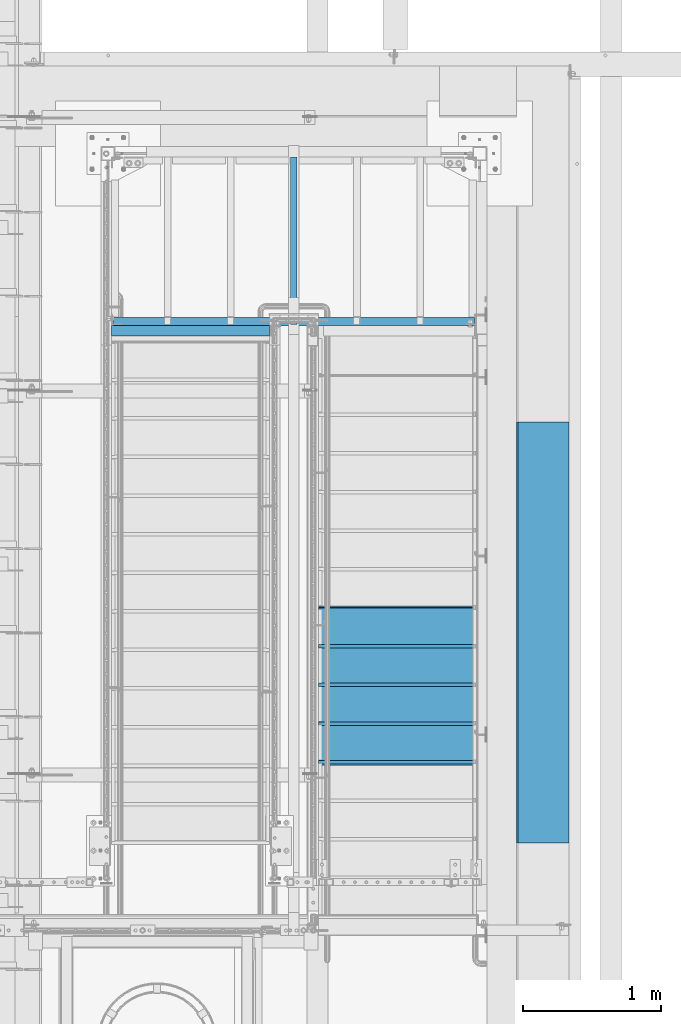
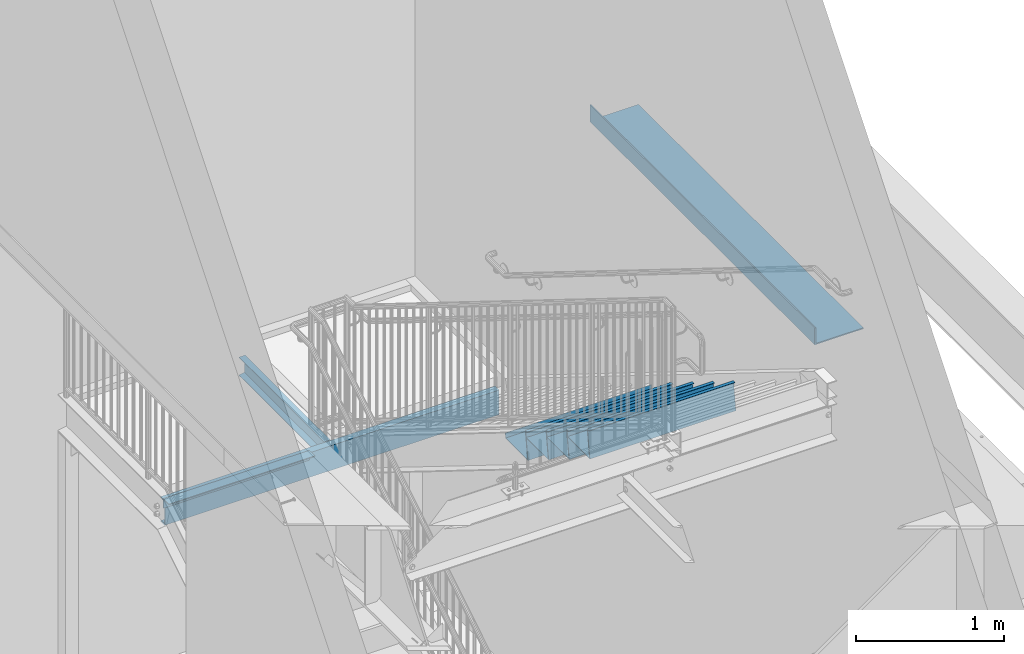
# One storey, part 1093 of 1763: 8 beams, 3 elements without a shape of their own.
"""IFC2X3 building model written with IfcOpenShell, lengths in millimetres."""

from ifc_helpers import new_model, si_unit, frame, origin_with_axes, place, context, subcontext, project, spatial, faceted_brep, material, type_object, element, aggregate, save


model = new_model("IFC2X3")

# Units and contexts
model_context = context("Model", 3, precision=1e-05, world=origin_with_axes())
body_context = subcontext(model_context, "Body", "Model", "MODEL_VIEW")
ifc_project = project(units=[si_unit("LENGTHUNIT", "METRE", prefix="MILLI"), si_unit("AREAUNIT", "SQUARE_METRE"), si_unit("VOLUMEUNIT", "CUBIC_METRE"), si_unit("MASSUNIT", "GRAM", prefix="KILO"), si_unit("TIMEUNIT", "SECOND"), si_unit("PLANEANGLEUNIT", "RADIAN"), si_unit("SOLIDANGLEUNIT", "STERADIAN"), si_unit("THERMODYNAMICTEMPERATUREUNIT", "DEGREE_CELSIUS"), si_unit("LUMINOUSINTENSITYUNIT", "LUMEN")], contexts=[model_context])

# Site, building, storey
site_placement = place(None, origin_with_axes())
site = spatial("IfcSite", under=ifc_project, at=site_placement, CompositionType="ELEMENT")
building_placement = place(site_placement, origin_with_axes())
building = spatial("IfcBuilding", under=site, at=building_placement, Name="Undefined", CompositionType="ELEMENT")
storey_placement = place(building_placement, origin_with_axes())
storey = spatial("IfcBuildingStorey", under=building, at=storey_placement, Name="Undefined", CompositionType="ELEMENT", Elevation=0.0)

# Assembly, beams
assembly_1_placement = place(storey_placement, origin_with_axes())
assembly_1 = element("IfcElementAssembly", 1, at=assembly_1_placement, inside=storey, Name="STRINGER", AssemblyPlace="NOTDEFINED", PredefinedType="RIGID_FRAME")
ifc_material = material(Name="STEEL/A36")
beam_type_1 = type_object("IfcBeamType", Name="C6X8.2", PredefinedType="NOTDEFINED")
beam_1_placement = place(assembly_1_placement, frame((-85419.637547451, 36061.6500002742, 2579.68749999999), z_axis=(0.0, 0.0, -1.0), x_axis=(0.0, 1.0, 0.0)))
beam_1 = element("IfcBeam", 2, at=beam_1_placement, type_object=beam_type_1, material=ifc_material, Name="BEAM", ObjectType="C6X8.2", context=body_context, shape_type="Brep", body=[
    faceted_brep([(57.1500002860994, -23.8125, -76.2000000013695), (53.1796626072537, -23.8125, -72.2296624999999), (50.800000858304, -9.52881209726911, -69.8500000954054), (50.800000858304, 23.8125, -69.8500000954054), (57.1500002860994, 23.8125, -76.1999999999998), (0.0, -23.8125, 72.2296624999999), (0.0, 19.0500000000029, 65.0887699999998), (1212.84999972743, 19.0500000000029, 65.0887699999998), (1212.84999972743, -23.8125, 72.2296624999999), (0.0, -23.8125, 76.1999999999998), (1212.84999972743, -23.8125, 76.1999999999998), (0.0, 23.8125, 76.1999999999998), (1212.84999972743, 23.8125, 76.1999999999998), (0.0, 23.8125, -50.8000003814695), (0.0, 19.0500000000029, -50.8000003814695), (38.1000010490388, 23.8125, -50.8000003814695), (38.1000010490388, 19.0500000000029, -50.8000003814695), (42.9600805670852, 23.8125, -51.7667303040575), (42.9600805670852, 19.0500000000029, -51.7667303040575), (47.0802570352389, 23.8125, -54.5197442045355), (47.0802570352389, 19.0500000000029, -54.5197442045355), (49.8332709357128, 23.8125, -58.6399206726892), (49.8332709357128, 19.0500000000029, -58.6399206726892), (50.800000858304, 23.8125, -63.5000001907347), (50.800000858304, 19.0500000000029, -63.5000001907347), (1212.84999972743, 19.0500000000029, -65.0887699999998), (50.800000858304, 19.0500000000029, -65.0887699999998), (1212.84999972743, -23.8125, -72.2296624999999), (1212.84999972743, -23.8125, -76.1999999999998), (1212.84999972743, 23.8125, -76.1999999999998)], [[[0, 1, 2, 3, 4]], [[5, 6, 7, 8]], [[9, 5, 8, 10]], [[11, 9, 10, 12]], [[6, 5, 9, 11, 13, 14]], [[14, 13, 15, 16]], [[16, 15, 17, 18]], [[18, 17, 19, 20]], [[20, 19, 21, 22]], [[22, 21, 23, 24]], [[25, 7, 6, 14, 16, 18, 20, 22, 24, 26]], [[10, 8, 7, 25, 27, 28, 29, 12]], [[29, 28, 0, 4]], [[23, 21, 19, 17, 15, 13, 11, 12, 29, 4, 3]], [[26, 24, 23, 3, 2]], [[27, 25, 26, 2, 1]], [[28, 27, 1, 0]]]),
])
beam_type_2 = type_object("IfcBeamType", Name="L3X3X1/4", PredefinedType="NOTDEFINED")
beam_2_placement = place(assembly_1_placement, frame((-85597.4372735365, 36017.2000003621, 2640.01249998947), z_axis=(0.0, 0.0, -1.0), x_axis=(-1.0, 0.0, 0.0)))
beam_2 = element("IfcBeam", 3, at=beam_2_placement, type_object=beam_type_2, material=ifc_material, Name="ANGLE", ObjectType="L3X3X1/4", context=body_context, shape_type="Brep", body=[
    faceted_brep([(0.0, 38.0999999999985, -38.1000000000004), (0.0, 38.0999999999985, 38.1000000000004), (1143.00000038925, 38.0999999999985, 38.0999999999999), (1143.00000038925, 38.0999999999985, -38.0999999999999), (0.0, 31.75, 38.1000000000058), (1143.00000038925, 31.75, 38.0999999999999), (0.0, 31.75, -31.75), (1143.00000038925, 31.75, -31.75), (0.0, -38.1000000000004, -31.75), (1143.00000038925, -38.0999999999985, -31.75), (0.0, -38.0999999999985, -38.1000000000004), (1143.00000038925, -38.0999999999985, -38.0999999999999)], [[[0, 1, 2, 3]], [[1, 4, 5, 2]], [[4, 6, 7, 5]], [[6, 8, 9, 7]], [[8, 10, 11, 9]], [[10, 0, 3, 11]], [[5, 7, 9, 11, 3, 2]], [[10, 8, 6, 4, 1, 0]]]),
])
beam_type_3 = type_object("IfcBeamType", Name="C8X11.5", PredefinedType="NOTDEFINED")
beam_3_placement = place(assembly_1_placement, frame((-84111.5372735079, 36083.8750003695, 2554.28750000009), z_axis=(0.0, 0.0, 1.0), x_axis=(-1.0, 0.0, 0.0)))
beam_3 = element("IfcBeam", 4, at=beam_3_placement, type_object=beam_type_3, material=ifc_material, Name="STRINGER", ObjectType="C8X11.5", context=body_context, shape_type="Brep", body=[
    faceted_brep([(0.0, 28.5749999999971, -101.6), (0.0, 28.5749999999971, 101.6), (2616.2000006086, 28.5749999999971, 101.6), (2616.2000006086, 28.5749999999971, -101.6), (0.0, -28.5749999999971, 101.6), (2616.2000006086, -28.5749999999971, 101.6), (0.0, -28.5749999999971, 96.835595), (2616.2000006086, -28.5749999999971, 96.835595), (0.0, 22.2249999999985, 88.3723150000001), (2616.2000006086, 22.2249999999985, 88.3723150000001), (0.0, 22.2249999999985, -88.3723150000001), (2616.2000006086, 22.2249999999985, -88.3723150000001), (0.0, -28.5749999999971, -96.835595), (2616.2000006086, -28.5749999999971, -96.835595), (0.0, -28.5749999999971, -101.6), (2616.2000006086, -28.5749999999971, -101.6)], [[[0, 1, 2, 3]], [[1, 4, 5, 2]], [[4, 6, 7, 5]], [[6, 8, 9, 7]], [[8, 10, 11, 9]], [[10, 12, 13, 11]], [[12, 14, 15, 13]], [[14, 0, 3, 15]], [[5, 7, 9, 11, 13, 15, 3, 2]], [[14, 12, 10, 8, 6, 4, 1, 0]]]),
])
aggregate(assembly_1, [beam_1, beam_2, beam_3])

# Assembly, beam
assembly_2_placement = place(storey_placement, origin_with_axes())
assembly_2 = element("IfcElementAssembly", 5, at=assembly_2_placement, inside=storey, Name="BEAM", AssemblyPlace="NOTDEFINED", PredefinedType="RIGID_FRAME")
beam_type_4 = type_object("IfcBeamType", PredefinedType="NOTDEFINED")
beam_4_placement = place(assembly_2_placement, frame((-83425.7372736983, 33832.00575, 5199.0625), z_axis=(0.0, -1.0, 0.0), x_axis=(-1.0, 0.0, 0.0)))
beam_4 = element("IfcBeam", 6, at=beam_4_placement, type_object=beam_type_4, material=ifc_material, Name="BENT_PLATE", context=body_context, shape_type="Brep", body=[
    faceted_brep([(0.0, -4.76249999999982, -1524.0), (0.0, -4.76249999999982, 1524.0), (0.0, 4.76249999999982, 1524.0), (0.0, 4.76249999999982, -1524.0), (381.0, 4.76249999999982, 1524.0), (381.0, 4.76249999999982, -1524.0), (371.475000000006, -4.76249999999982, -1524.0), (371.475000000006, -4.76249999999982, 1524.0), (381.0, -134.937496948242, 1524.0), (381.0, -134.937496948242, -1524.0), (371.475000000006, -134.937496948242, 1524.0), (371.475000000006, -134.937496948242, -1524.0)], [[[0, 1, 2, 3]], [[3, 2, 4, 5]], [[1, 0, 6, 7]], [[5, 4, 8, 9]], [[4, 2, 1, 7, 10, 8]], [[7, 6, 11, 10]], [[6, 0, 3, 5, 9, 11]], [[10, 11, 9, 8]]]),
])
aggregate(assembly_2, [beam_4])

# Assembly, beams
assembly_3_placement = place(storey_placement, origin_with_axes())
assembly_3 = element("IfcElementAssembly", 7, at=assembly_3_placement, inside=storey, Name="STRINGER", AssemblyPlace="NOTDEFINED", PredefinedType="RIGID_FRAME")
beam_type_5 = type_object("IfcBeamType", PredefinedType="NOTDEFINED")
beam_5_placement = place(assembly_3_placement, frame((-84670.272101313, 32880.3000003324, 4638.56916667991), z_axis=(-1.0, 0.0, 0.0), x_axis=(0.0, 1.0, 0.0)))
beam_5 = element("IfcBeam", 8, at=beam_5_placement, type_object=beam_type_5, material=ifc_material, Name="TREAD", context=body_context, shape_type="Brep", body=[
    faceted_brep([(0.0, -1.58749999999964, -571.5), (0.0, -1.58749999999964, 571.5), (0.0, 1.58749999999964, 571.5), (0.0, 1.58749999999964, -571.5), (21.7262234107766, 1.58750000001965, 571.5), (21.7262234107766, 1.58750000001965, -571.5), (25.3999996185303, -1.58749999999998, -571.5), (25.3999996185303, -1.58749999999998, 571.5), (-11.1124582870689, 225.848333740234, 571.5), (-11.1124582870689, 225.848333740234, -571.5), (-7.43868207930791, 222.673333740234, -571.5), (-7.43868207930791, 222.673333740234, 571.5), (293.687544632128, 225.848333740234, 571.5), (293.687544632128, 225.848333740234, -571.5), (290.943603515625, 222.673333740234, -571.5), (290.943603515625, 222.673333740234, 571.5), (299.605243823971, 185.435362772942, 571.5), (299.605243823971, 185.435362772942, -571.5), (296.463745117188, 184.975350952148, 571.5), (296.463745117188, 184.975350952148, -571.5)], [[[0, 1, 2, 3]], [[3, 2, 4, 5]], [[1, 0, 6, 7]], [[5, 4, 8, 9]], [[7, 6, 10, 11]], [[9, 8, 12, 13]], [[11, 10, 14, 15]], [[13, 12, 16, 17]], [[12, 8, 4, 2, 1, 7, 11, 15, 18, 16]], [[15, 14, 19, 18]], [[14, 10, 6, 0, 3, 5, 9, 13, 17, 19]], [[18, 19, 17, 16]]]),
])
beam_6_placement = place(assembly_3_placement, frame((-84670.272101313, 33159.7000004163, 4465.10833334658), z_axis=(-1.0, 0.0, 0.0), x_axis=(0.0, 1.0, 0.0)))
beam_6 = element("IfcBeam", 9, at=beam_6_placement, type_object=beam_type_5, material=ifc_material, Name="TREAD", context=body_context, shape_type="Brep", body=[
    faceted_brep([(0.0, -1.58749999999964, -571.5), (0.0, -1.58749999999964, 571.5), (0.0, 1.58749999999964, 571.5), (0.0, 1.58749999999964, -571.5), (21.7262234107766, 1.58750000001965, 571.5), (21.7262234107766, 1.58750000001965, -571.5), (25.3999996185303, -1.58749999999998, -571.5), (25.3999996185303, -1.58749999999998, 571.5), (-11.1124582870689, 225.848333740234, 571.5), (-11.1124582870689, 225.848333740234, -571.5), (-7.43868207930791, 222.673333740234, -571.5), (-7.43868207930791, 222.673333740234, 571.5), (293.687544632128, 225.848333740234, 571.5), (293.687544632128, 225.848333740234, -571.5), (290.943603515625, 222.673333740234, -571.5), (290.943603515625, 222.673333740234, 571.5), (299.605243823971, 185.435362772942, 571.5), (299.605243823971, 185.435362772942, -571.5), (296.463745117188, 184.975350952148, 571.5), (296.463745117188, 184.975350952148, -571.5)], [[[0, 1, 2, 3]], [[3, 2, 4, 5]], [[1, 0, 6, 7]], [[5, 4, 8, 9]], [[7, 6, 10, 11]], [[9, 8, 12, 13]], [[11, 10, 14, 15]], [[13, 12, 16, 17]], [[12, 8, 4, 2, 1, 7, 11, 15, 18, 16]], [[15, 14, 19, 18]], [[14, 10, 6, 0, 3, 5, 9, 13, 17, 19]], [[18, 19, 17, 16]]]),
])
beam_7_placement = place(assembly_3_placement, frame((-84670.272101313, 33439.1000005002, 4291.64750001325), z_axis=(-1.0, 0.0, 0.0), x_axis=(0.0, 1.0, 0.0)))
beam_7 = element("IfcBeam", 10, at=beam_7_placement, type_object=beam_type_5, material=ifc_material, Name="TREAD", context=body_context, shape_type="Brep", body=[
    faceted_brep([(0.0, -1.58749999999964, -571.5), (0.0, -1.58749999999964, 571.5), (0.0, 1.58749999999964, 571.5), (0.0, 1.58749999999964, -571.5), (21.7262234107766, 1.58750000001965, 571.5), (21.7262234107766, 1.58750000001965, -571.5), (25.3999996185303, -1.58749999999998, -571.5), (25.3999996185303, -1.58749999999998, 571.5), (-11.1124582870689, 225.848333740234, 571.5), (-11.1124582870689, 225.848333740234, -571.5), (-7.43868207930791, 222.673333740234, -571.5), (-7.43868207930791, 222.673333740234, 571.5), (293.687544632128, 225.848333740234, 571.5), (293.687544632128, 225.848333740234, -571.5), (290.943603515625, 222.673333740234, -571.5), (290.943603515625, 222.673333740234, 571.5), (299.605243823971, 185.435362772942, 571.5), (299.605243823971, 185.435362772942, -571.5), (296.463745117188, 184.975350952148, 571.5), (296.463745117188, 184.975350952148, -571.5)], [[[0, 1, 2, 3]], [[3, 2, 4, 5]], [[1, 0, 6, 7]], [[5, 4, 8, 9]], [[7, 6, 10, 11]], [[9, 8, 12, 13]], [[11, 10, 14, 15]], [[13, 12, 16, 17]], [[12, 8, 4, 2, 1, 7, 11, 15, 18, 16]], [[15, 14, 19, 18]], [[14, 10, 6, 0, 3, 5, 9, 13, 17, 19]], [[18, 19, 17, 16]]]),
])
beam_8_placement = place(assembly_3_placement, frame((-84670.272101313, 33718.5000005841, 4118.18666667991), z_axis=(-1.0, 0.0, 0.0), x_axis=(0.0, 1.0, 0.0)))
beam_8 = element("IfcBeam", 11, at=beam_8_placement, type_object=beam_type_5, material=ifc_material, Name="TREAD", context=body_context, shape_type="Brep", body=[
    faceted_brep([(0.0, -1.58749999999964, -571.5), (0.0, -1.58749999999964, 571.5), (0.0, 1.58749999999964, 571.5), (0.0, 1.58749999999964, -571.5), (21.7262234107766, 1.58750000001965, 571.5), (21.7262234107766, 1.58750000001965, -571.5), (25.3999996185303, -1.58749999999998, -571.5), (25.3999996185303, -1.58749999999998, 571.5), (-11.1124582870689, 225.848333740234, 571.5), (-11.1124582870689, 225.848333740234, -571.5), (-7.43868207930791, 222.673333740234, -571.5), (-7.43868207930791, 222.673333740234, 571.5), (293.687544632128, 225.848333740234, 571.5), (293.687544632128, 225.848333740234, -571.5), (290.943603515625, 222.673333740234, -571.5), (290.943603515625, 222.673333740234, 571.5), (299.605243823971, 185.435362772942, 571.5), (299.605243823971, 185.435362772942, -571.5), (296.463745117188, 184.975350952148, 571.5), (296.463745117188, 184.975350952148, -571.5)], [[[0, 1, 2, 3]], [[3, 2, 4, 5]], [[1, 0, 6, 7]], [[5, 4, 8, 9]], [[7, 6, 10, 11]], [[9, 8, 12, 13]], [[11, 10, 14, 15]], [[13, 12, 16, 17]], [[12, 8, 4, 2, 1, 7, 11, 15, 18, 16]], [[15, 14, 19, 18]], [[14, 10, 6, 0, 3, 5, 9, 13, 17, 19]], [[18, 19, 17, 16]]]),
])
aggregate(assembly_3, [beam_5, beam_6, beam_7, beam_8])

save(model, "model.ifc")
